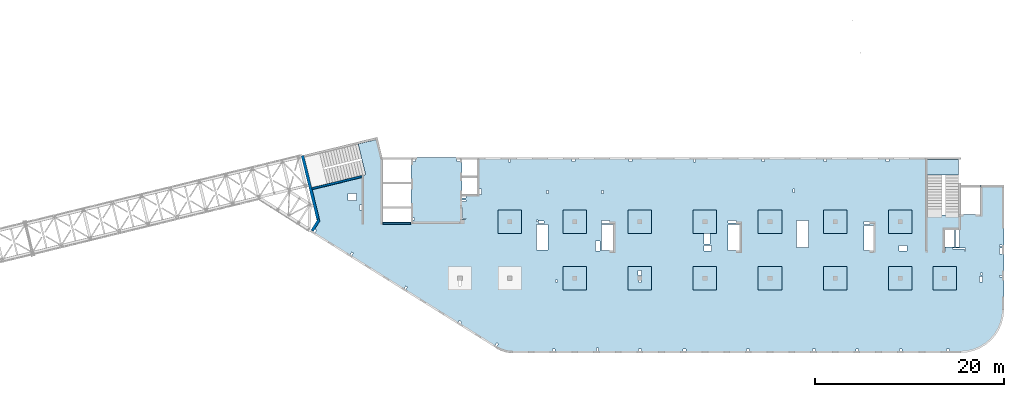
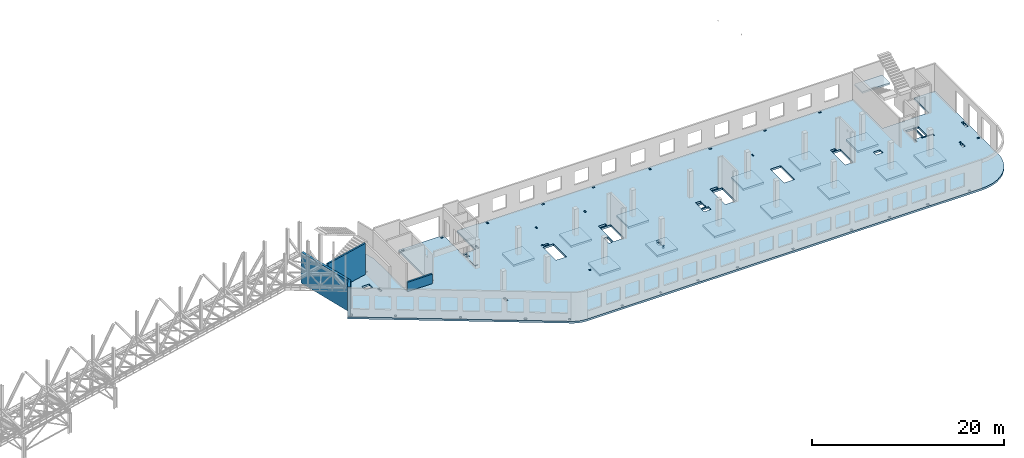
# One storey, part 20 of 92: 16 slabs, 4 walls.
"""IFC4 building model written with IfcOpenShell, lengths in millimetres."""

from ifc_helpers import new_model, entity, si_unit, converted_unit, derived_unit, direction, frame, origin, place, context, subcontext, project, spatial, indexed_curve, outline, extrude, material, type_object, element, save


model = new_model("IFC4")

# Units and contexts
model_context = context("Model", 3, precision=0.01, world=origin(), true_north=direction((6.12303176911189e-17, 1.0)))
plan_context = context("Plan", 3, precision=0.01, world=origin(), true_north=direction((6.12303176911189e-17, 1.0)))
body_context = subcontext(model_context, "Body", "Model", "MODEL_VIEW")
ifc_project = project(units=[si_unit("LENGTHUNIT", "METRE", prefix="MILLI"), si_unit("AREAUNIT", "SQUARE_METRE"), si_unit("VOLUMEUNIT", "CUBIC_METRE"), converted_unit("PLANEANGLEUNIT", "DEGREE", entity("IfcRatioMeasure", 0.0174532925199433), si_unit("PLANEANGLEUNIT", "RADIAN"), dimensions=[0, 0, 0, 0, 0, 0, 0]), si_unit("MASSUNIT", "GRAM", prefix="KILO"), derived_unit("MASSDENSITYUNIT", [(si_unit("MASSUNIT", "GRAM", prefix="KILO"), 1), (si_unit("LENGTHUNIT", "METRE"), -3)]), derived_unit("MOMENTOFINERTIAUNIT", [(si_unit("LENGTHUNIT", "METRE"), 4)]), si_unit("TIMEUNIT", "SECOND"), si_unit("FREQUENCYUNIT", "HERTZ"), si_unit("THERMODYNAMICTEMPERATUREUNIT", "DEGREE_CELSIUS"), derived_unit("THERMALTRANSMITTANCEUNIT", [(si_unit("MASSUNIT", "GRAM", prefix="KILO"), 1), (si_unit("THERMODYNAMICTEMPERATUREUNIT", "KELVIN"), -1), (si_unit("TIMEUNIT", "SECOND"), -3)]), derived_unit("VOLUMETRICFLOWRATEUNIT", [(si_unit("LENGTHUNIT", "METRE"), 3), (si_unit("TIMEUNIT", "SECOND"), -1)]), derived_unit("MASSFLOWRATEUNIT", [(si_unit("MASSUNIT", "GRAM", prefix="KILO"), 1), (si_unit("TIMEUNIT", "SECOND"), -1)]), derived_unit("ROTATIONALFREQUENCYUNIT", [(si_unit("TIMEUNIT", "SECOND"), -1)]), si_unit("ELECTRICCURRENTUNIT", "AMPERE"), si_unit("ELECTRICVOLTAGEUNIT", "VOLT"), si_unit("POWERUNIT", "WATT"), si_unit("FORCEUNIT", "NEWTON", prefix="KILO"), si_unit("ILLUMINANCEUNIT", "LUX"), si_unit("LUMINOUSFLUXUNIT", "LUMEN"), si_unit("LUMINOUSINTENSITYUNIT", "CANDELA"), derived_unit("USERDEFINED", [(si_unit("MASSUNIT", "GRAM", prefix="KILO"), -1), (si_unit("LENGTHUNIT", "METRE"), -2), (si_unit("TIMEUNIT", "SECOND"), 3), (si_unit("LUMINOUSFLUXUNIT", "LUMEN"), 1)]), derived_unit("LINEARVELOCITYUNIT", [(si_unit("LENGTHUNIT", "METRE"), 1), (si_unit("TIMEUNIT", "SECOND"), -1)]), si_unit("PRESSUREUNIT", "PASCAL"), derived_unit("USERDEFINED", [(si_unit("LENGTHUNIT", "METRE"), -2), (si_unit("MASSUNIT", "GRAM", prefix="KILO"), 1), (si_unit("TIMEUNIT", "SECOND"), -2)]), derived_unit("LINEARFORCEUNIT", [(si_unit("MASSUNIT", "GRAM", prefix="KILO"), 1), (si_unit("LENGTHUNIT", "METRE"), 1), (si_unit("TIMEUNIT", "SECOND"), -2), (si_unit("LENGTHUNIT", "METRE"), -1)]), derived_unit("PLANARFORCEUNIT", [(si_unit("MASSUNIT", "GRAM", prefix="KILO"), 1), (si_unit("LENGTHUNIT", "METRE"), 1), (si_unit("TIMEUNIT", "SECOND"), -2), (si_unit("LENGTHUNIT", "METRE"), -2)])], contexts=[model_context, plan_context])

# Site, building, storey
site_placement = place(None, origin())
site = spatial("IfcSite", under=ifc_project, at=site_placement, CompositionType="ELEMENT")
building_placement = place(site_placement, origin())
building = spatial("IfcBuilding", under=site, at=building_placement, CompositionType="ELEMENT")
storey_placement = place(building_placement, frame((0.0, 0.0, 15900.0)))
storey = spatial("IfcBuildingStorey", under=building, at=storey_placement, Name="05", CompositionType="ELEMENT", Elevation=15900.0)

# Slabs
ifc_material = material()
slab_type_1 = type_object("IfcSlabType", Name=":ADSK_ 25_250", PredefinedType="FLOOR", material=ifc_material)
placement = place(storey_placement, origin())
element("IfcSlab", 1, at=placement, inside=storey, type_object=slab_type_1, material=ifc_material, Name=":ADSK_ 25_250", ObjectType=":ADSK_ 25_250", PredefinedType="FLOOR", context=body_context, shape_type="SweptSolid", body=[
    extrude(outline(indexed_curve([(-11615.3456191022, -15866.2384672249), (-11461.2227621515, -15956.6617307079), (-11302.2940263976, -16038.3432987954), (-11139.0547290428, -16111.0286027615), (-10972.0136215827, -16174.4911116315), (-10801.6913042325, -16228.5330381886), (-10628.6186034238, -16272.985955397), (-10453.3349174317, -16307.7113213217), (-10276.3865352866, -16332.6009109081), (-10098.3249342096, -16347.5771532763), (-9919.70506087959, -16352.5933734784), (37585.2949391216, -16352.5933734786), (38304.8933503634, -16295.9597502856), (39006.7728605103, -16127.4533884657), (39673.6508666178, -15851.2234738877), (40289.1066189344, -15474.0717038028), (40837.9855542575, -15005.2848064856), (41306.7724515748, -14456.4058711625), (41683.9242216596, -13840.9501188459), (41960.1541362377, -13174.0721127383), (42128.6604980575, -12472.1926025915), (42185.2941212505, -11752.5941913496), (42185.2941212505, 1417.40662652148), (39685.2941212505, 1417.40662652149), (39685.2941212505, -1682.59337347851), (37385.2949391216, -1682.59337347851), (37385.2949391216, -1722.59337347848), (34045.2949391217, -1722.59337347847), (34045.2949391217, 4347.4072658887), (-13659.7050608784, 4347.40726588886), (-13659.7050608784, 447.406626521855), (-15284.7050608784, 447.406626521859), (-15284.7050608784, 4347.40726588869), (-20684.7050608784, 4347.40726588871), (-20684.7050608784, -2502.5933734781), (-23684.7050608784, -2502.59337347809), (-23684.7050608784, 4347.40726588869), (-23734.0606732206, 4347.40726588869), (-24254.10794231, 6480.84192351009), (-24448.4183539383, 6433.47670491202), (-24401.0531353402, 6239.16629328373), (-26276.1486075532, 5782.09193381237), (-25485.1529405355, 2537.12235056864), (-31479.6214345329, 1075.90723492907), (-30648.3195083992, -2334.4141830962), (-31384.8454167592, -3513.12502953493), (-11615.3456191022, -15866.2384672249)], self_intersect=False), holes=[indexed_curve([(-26424.7050608784, -192.593373478052), (-27324.7050608784, -192.593373478052), (-27324.7050608784, 507.406626521949), (-26424.7050608784, 507.406626521947), (-26424.7050608784, -192.593373478052)], self_intersect=False), indexed_curve([(-25884.7050608784, -667.593373478048), (-25884.7050608784, -1227.59337347805), (-26134.7050608784, -1227.59337347805), (-26134.7050608784, -667.593373478048), (-25884.7050608784, -667.593373478048)], self_intersect=False), indexed_curve([(-30865.4736804199, -3248.07220556975), (-30695.8631316644, -3354.05457085215), (-30854.836679588, -3608.47039398543), (-31024.4472283436, -3502.48802870303), (-30865.4736804199, -3248.07220556975)], self_intersect=False), indexed_curve([(-26955.9505316053, -5690.96572532919), (-26786.3399828498, -5796.94809061159), (-26945.3135307734, -6051.36391374487), (-27114.9240795289, -5945.38154846246), (-26955.9505316053, -5690.96572532919)], self_intersect=False), indexed_curve([(-21223.1139836689, -9273.16967187448), (-21053.5034349134, -9379.15203715688), (-21212.476982837, -9633.56786029016), (-21382.0875315925, -9527.58549500775), (-21223.1139836689, -9273.16967187448)], self_intersect=False), indexed_curve([(-15551.7491458115, -12934.8797745334), (-15297.3333226782, -13093.853322457), (-15403.3156879606, -13263.4638712125), (-15657.7315110939, -13104.4903232889), (-15551.7491458115, -12934.8797745334)], self_intersect=False), indexed_curve([(-11580.7542869179, -15298.2671381792), (-11411.1437381624, -15404.2495034616), (-11570.117286086, -15658.6653265949), (-11739.7278348415, -15552.6829613125), (-11580.7542869179, -15298.2671381792)], self_intersect=False), indexed_curve([(-5384.7050608784, -16152.5933734782), (-5684.7050608784, -16152.5933734782), (-5684.7050608784, -15952.5933734782), (-5384.7050608784, -15952.5933734782), (-5384.7050608784, -16152.5933734782)], self_intersect=False), indexed_curve([(-789.705060878393, -16152.5933734782), (-989.705060878395, -16152.5933734782), (-989.705060878386, -15852.5933734782), (-789.705060878388, -15852.5933734782), (-789.705060878393, -16152.5933734782)], self_intersect=False), indexed_curve([(3735.29493912161, -16152.5933734782), (3435.29493912161, -16152.5933734782), (3435.29493912161, -15952.5933734782), (3735.29493912161, -15952.5933734782), (3735.29493912161, -16152.5933734782)], self_intersect=False), indexed_curve([(8485.29493912161, -16152.5933734783), (8185.29493912161, -16152.5933734782), (8185.29493912161, -15952.5933734782), (8485.29493912161, -15952.5933734783), (8485.29493912161, -16152.5933734783)], self_intersect=False), indexed_curve([(15185.2949391216, -16152.5933734783), (14885.2949391216, -16152.5933734782), (14885.2949391216, -15952.5933734783), (15185.2949391216, -15952.5933734783), (15185.2949391216, -16152.5933734783)], self_intersect=False), indexed_curve([(22185.2949391216, -16152.5933734783), (21885.2949391216, -16152.5933734783), (21885.2949391216, -15952.5933734783), (22185.2949391216, -15952.5933734783), (22185.2949391216, -16152.5933734783)], self_intersect=False), indexed_curve([(26785.2949391216, -16152.5933734783), (26485.2949391216, -16152.5933734783), (26485.2949391216, -15952.5933734783), (26785.2949391216, -15952.5933734783), (26785.2949391216, -16152.5933734783)], self_intersect=False), indexed_curve([(31385.2949391216, -16152.5933734783), (31085.2949391216, -16152.5933734783), (31085.2949391216, -15952.5933734783), (31385.2949391216, -15952.5933734783), (31385.2949391216, -16152.5933734783)], self_intersect=False), indexed_curve([(36385.2949391216, -16152.5933734783), (36085.2949391216, -16152.5933734783), (36085.2949391216, -15952.5933734783), (36385.2949391216, -15952.5933734783), (36385.2949391216, -16152.5933734783)], self_intersect=False), indexed_curve([(-20184.7050608784, 4147.4072658887), (-20184.7050608784, 3947.4072658887), (-20484.7050608784, 3947.40726588869), (-20484.7050608784, 4147.4072658887), (-20184.7050608784, 4147.4072658887)], self_intersect=False), indexed_curve([(-20284.7050608784, -2252.59337347809), (-20484.7050608784, -2252.59337347809), (-20484.7050608784, -2052.59337347809), (-20284.7050608784, -2052.59337347809), (-20284.7050608784, -2252.59337347809)], self_intersect=False), indexed_curve([(-15784.7050608784, 4147.4072658887), (-15484.7050608784, 4147.4072658887), (-15484.7050608784, 3947.4072658887), (-15784.7050608784, 3947.4072658887), (-15784.7050608784, 4147.4072658887)], self_intersect=False), indexed_curve([(-14854.7050608784, 247.406626521861), (-14854.7050608784, 47.4066265218589), (-15284.7050608784, 47.4066265218589), (-15284.7050608784, 247.406626521859), (-14854.7050608784, 247.406626521861)], self_intersect=False), indexed_curve([(-14854.7050608784, -177.593373478142), (-14854.7050608784, -337.59337347814), (-15284.7050608784, -337.59337347814), (-15284.7050608784, -177.593373478142), (-14854.7050608784, -177.593373478142)], self_intersect=False), indexed_curve([(-15284.7050608784, -2182.59337347814), (-15284.7050608784, -992.593373478139), (-15204.7050608784, -992.593373478139), (-15204.7050608784, -2102.59337347814), (-14864.7050608784, -2102.59337347814), (-14864.7050608784, -2182.59337347814), (-15284.7050608784, -2182.59337347814)], self_intersect=False), indexed_curve([(-13209.7050608784, 447.406626521855), (-13459.7050608784, 447.406626521855), (-13459.7050608784, 1007.40662652186), (-13209.7050608784, 1007.40662652186), (-13209.7050608784, 447.406626521855)], self_intersect=False), indexed_curve([(-10314.7050608784, 4147.4072658887), (-10214.7050608784, 4147.4072658887), (-10114.7050608784, 4147.40662652183), (-10114.7050608784, 3847.40726588869), (-10314.7050608784, 3847.40726588869), (-10314.7050608784, 4147.4072658887)], self_intersect=False), indexed_curve([(-3614.70506087836, 4147.40662652179), (-3314.70506087836, 4147.40662652179), (-3314.70506087836, 3947.40662652179), (-3614.70506087836, 3947.40662652179), (-3614.70506087836, 4147.40662652179)], self_intersect=False), indexed_curve([(2460.29493912165, 4147.40662652177), (2760.29493912165, 4147.40662652177), (2760.29493912164, 3947.40662652177), (2460.29493912164, 3947.40662652176), (2460.29493912165, 4147.40662652177)], self_intersect=False), indexed_curve([(16510.2949391216, 4147.40662652173), (16810.2949391216, 4147.40662652172), (16810.2949391216, 3947.40662652171), (16510.2949391216, 3947.40662652172), (16510.2949391216, 4147.40662652173)], self_intersect=False), indexed_curve([(9260.29493912165, 4147.4066265217), (9460.29493912165, 4147.4066265217), (9460.29493912166, 3847.4066265217), (9260.29493912165, 3847.4066265217), (9260.29493912165, 4147.4066265217)], self_intersect=False), indexed_curve([(23085.2949391216, 4147.40662652169), (23385.2949391216, 4147.40662652169), (23385.2949391216, 3947.4066265217), (23085.2949391216, 3947.4066265217), (23085.2949391216, 4147.40662652169)], self_intersect=False), indexed_curve([(29685.2949391216, 4147.40662652168), (29985.2949391216, 4147.40662652167), (29985.2949391216, 3947.40662652167), (29685.2949391216, 3947.40662652167), (29685.2949391216, 4147.40662652168)], self_intersect=False), indexed_curve([(-6114.70506087836, 847.407265888692), (-6114.70506087836, 527.407265888689), (-6314.70506087837, 527.407265888691), (-6314.70506087837, 847.407265888695), (-6114.70506087836, 847.407265888692)], self_intersect=False), indexed_curve([(-264.705060878365, 867.407265888811), (-264.70506087836, 507.407265888813), (-464.705060878358, 507.407265888813), (-464.705060878358, 867.407265888811), (-264.705060878365, 867.407265888811)], self_intersect=False), indexed_curve([(19975.2949391216, 997.407265888704), (19975.2949391216, 647.407265888701), (19825.2949391216, 647.407265888701), (19825.2949391216, 997.407265888704), (19975.2949391216, 997.407265888704)], self_intersect=False), indexed_curve([(37055.2949391217, -5127.59337347849), (37055.2949391217, -3322.59337347848), (37385.2949391216, -3322.59337347849), (37445.2949391217, -3322.59337347849), (37445.2949391217, -5127.59337347849), (37055.2949391217, -5127.59337347849)], self_intersect=False), indexed_curve([(35975.2949391217, -5247.59337347849), (35975.2949391217, -5587.59337347849), (35895.2949391217, -5587.59337347849), (35895.2949391217, -5247.59337347849), (35975.2949391217, -5247.59337347849)], self_intersect=False), indexed_curve([(38095.2949391216, -5247.59337347848), (38095.2949391216, -5587.59337347848), (38015.2949391216, -5587.59337347849), (38015.2949391216, -5327.59337347848), (36715.2949391216, -5327.59337347848), (36715.2949391216, -5247.59337347849), (38095.2949391216, -5247.59337347848)], self_intersect=False), indexed_curve([(41685.2941212505, -8342.59337347853), (41685.2941212505, -8142.59337347853), (41985.2941212505, -8142.59337347853), (41985.2941212505, -8342.59337347853), (41685.2941212505, -8342.59337347853)], self_intersect=False), indexed_curve([(41685.2941212505, -5102.59337347853), (41685.2941212505, -4902.59337347852), (41985.2941212505, -4902.59337347853), (41985.2941212505, -5102.59337347853), (41685.2941212505, -5102.59337347853)], self_intersect=False), indexed_curve([(41685.2941212505, -5867.59337347854), (41685.2941212505, -5267.59337347853), (41985.2941212505, -5267.59337347854), (41985.2941212505, -5867.59337347854), (41685.2941212505, -5867.59337347854)], self_intersect=False), indexed_curve([(39895.2941212505, -8272.5933734785), (39895.2941212505, -8852.59337347852), (39595.2941212505, -8852.59337347852), (39595.2941212505, -8272.59337347851), (39895.2941212505, -8272.5933734785)], self_intersect=False), indexed_curve([(39905.2941212505, -7892.59337347851), (39905.2941212505, -8092.59337347851), (39705.2941212505, -8092.59337347851), (39705.2941212505, -7892.5933734785), (39905.2941212505, -7892.59337347851)], self_intersect=False), indexed_curve([(31900.2949391216, -4967.59337347845), (31900.2949391216, -5567.59337347845), (31070.2949391216, -5567.59337347845), (31070.2949391216, -4967.59337347845), (31900.2949391216, -4967.59337347845)], self_intersect=False), indexed_curve([(27345.2949391216, -5527.59337347843), (27345.2949391216, -2857.59337347842), (28345.2949391217, -2857.59337347842), (28345.2949391217, -5527.59337347844), (27345.2949391216, -5527.59337347843)], self_intersect=False), indexed_curve([(27345.2949391216, -2452.59337347842), (27945.2949391216, -2452.59337347842), (27945.2949391216, -2737.59337347842), (27345.2949391216, -2737.59337347842), (27345.2949391216, -2452.59337347842)], self_intersect=False), indexed_curve([(21465.2949391216, -2317.59337347838), (21465.2949391216, -5177.59337347839), (20205.2949391216, -5177.59337347839), (20205.2949391216, -2317.59337347838), (21465.2949391216, -2317.59337347838)], self_intersect=False), indexed_curve([(12925.2949391216, -5527.59322391854), (12925.2949391216, -2752.59322391854), (14185.2949391216, -2752.59322391854), (14185.2949391216, -5527.59322391853), (12925.2949391216, -5527.59322391854)], self_intersect=False), indexed_curve([(12925.2949391216, -2602.59337347834), (12925.2949391216, -2312.59337347833), (13785.2949391216, -2312.59337347833), (13785.2949391216, -2602.59337347834), (12925.2949391216, -2602.59337347834)], self_intersect=False), indexed_curve([(10395.2949391217, -3702.59337347839), (10485.2949391216, -3702.59337347838), (11015.2949391216, -3702.59337347839), (11015.2949391216, -4822.59337347839), (10395.2949391217, -4822.59337347839), (10395.2949391217, -3702.59337347839)], self_intersect=False), indexed_curve([(10370.2949391216, -4967.59337347839), (11200.2949391216, -4967.59337347839), (11200.2949391216, -5567.59337347838), (10370.2949391216, -5567.59337347839), (10370.2949391216, -4967.59337347839)], self_intersect=False), indexed_curve([(3485.29493912162, -8702.59337347826), (3585.29493912162, -8702.59337347826), (3685.29493912163, -8702.59337347826), (3685.29493912163, -8902.59337347827), (3485.29493912163, -8902.59337347827), (3485.29493912162, -8702.59337347826)], self_intersect=False), indexed_curve([(3405.29493912162, -8162.59337347827), (3405.29493912162, -7652.59337347826), (3735.29493912162, -7652.59337347827), (3735.29493912162, -8162.59337347826), (3405.29493912162, -8162.59337347827)], self_intersect=False), indexed_curve([(-474.705060878365, -5527.5932239185), (-474.705060878365, -2752.5932239185), (785.29493912163, -2752.5932239185), (785.294939121635, -5527.59322391849), (-474.705060878365, -5527.5932239185)], self_intersect=False), indexed_curve([(-474.705060878365, -2312.59337347824), (385.29493912163, -2312.59337347824), (385.294939121626, -2632.59337347824), (-474.705060878369, -2632.59337347824), (-474.705060878365, -2312.59337347824)], self_intersect=False), indexed_curve([(-1094.70506087836, -5567.5932239185), (-1094.70506087837, -4477.5932239185), (-634.705060878363, -4477.5932239185), (-634.705060878363, -5567.5932239185), (-1094.70506087836, -5567.5932239185)], self_intersect=False), indexed_curve([(-5134.70506087838, -8662.5933734782), (-5134.70506087839, -8862.5933734782), (-5334.70506087839, -8862.5933734782), (-5334.70506087839, -8662.5933734782), (-5134.70506087838, -8662.5933734782)], self_intersect=False), indexed_curve([(-6134.70506087837, -2752.59337347818), (-6134.70506087837, -5462.59337347818), (-7394.70506087837, -5462.59337347818), (-7394.70506087837, -2752.59337347818), (-6134.70506087837, -2752.59337347818)], self_intersect=False), indexed_curve([(-7194.70506087837, -2462.59337347819), (-7394.70506087837, -2462.59337347819), (-7394.70506087837, -2272.59337347818), (-7194.70506087837, -2272.59337347818), (-7194.70506087837, -2462.59337347819)], self_intersect=False), indexed_curve([(-6594.70506087837, -2632.59337347819), (-7154.70506087837, -2632.59337347819), (-7154.70506087837, -2382.5933734782), (-6594.70506087837, -2382.5933734782), (-6594.70506087837, -2632.59337347819)], self_intersect=False), indexed_curve([(36935.2949391217, -3322.59337347849), (36935.2949391217, -5127.59337347849), (35895.2949391217, -5127.59337347849), (35895.2949391217, -3322.59337347849), (36935.2949391217, -3322.59337347849)], self_intersect=False), indexed_curve([(-15644.7050608784, -8702.59337347814), (-15484.7050608784, -8702.59337347813), (-15394.7050608784, -8702.59337347813), (-15394.7050608784, -9262.59337347813), (-15644.7050608784, -9262.59337347814), (-15644.7050608784, -8702.59337347814)], self_intersect=False)]), frame((31384.71, 16152.59, -400.0)), (0.0, 0.0, 1.0), 249.999999999999),
])
slab_type_2 = type_object("IfcSlabType", Name=":ADSK_ 25_250", PredefinedType="FLOOR", material=ifc_material)
element("IfcSlab", 2, at=placement, inside=storey, type_object=slab_type_2, material=ifc_material, Name=":ADSK_ 25_250", ObjectType=":ADSK_ 25_250", PredefinedType="FLOOR", context=body_context, shape_type="SweptSolid", body=[
    extrude(outline(indexed_curve([(-1250.0, -1250.0), (1250.0, -1250.0), (1250.0, 1250.0), (-1250.0, 1250.0), (-1250.0, -1250.0)], self_intersect=False)), frame((28070.0, 7700.0, -400.0), z_axis=(0.0, 0.0, -1.0), x_axis=(0.0, 1.0, 0.0)), (0.0, 0.0, 1.0), 249.999999999999),
])
slab_type_3 = type_object("IfcSlabType", Name=":ADSK_ 25_250", PredefinedType="FLOOR", material=ifc_material)
element("IfcSlab", 3, at=placement, inside=storey, type_object=slab_type_3, material=ifc_material, Name=":ADSK_ 25_250", ObjectType=":ADSK_ 25_250", PredefinedType="FLOOR", context=body_context, shape_type="SweptSolid", body=[
    extrude(outline(indexed_curve([(-999.999999999999, -1250.00000000001), (1500.0, -1250.00000000001), (1500.0, 1250.0), (-999.999999999999, 1250.0), (-1000.0, -6.064055924071e-12), (-999.999999999999, -1250.00000000001)], self_intersect=False), holes=[indexed_curve([(500.000000000073, 99.9999999999998), (700.000000000076, 100.0), (700.000000000076, -100.000000000002), (500.000000000074, -100.000000000002), (500.000000000073, 99.9999999999998)], self_intersect=False), indexed_curve([(-549.999999999928, 149.999999999991), (-39.9999999999262, 149.999999999992), (-39.9999999999256, -180.000000000007), (-549.999999999928, -180.000000000008), (-549.999999999928, 149.999999999991)], self_intersect=False)]), frame((34970.0, 7950.0, -650.0), z_axis=(0.0, 0.0, 1.0), x_axis=(0.0, -1.0, 0.0)), (0.0, 0.0, 1.0), 249.999999999999),
])
slab_type_4 = type_object("IfcSlabType", Name=":ADSK_ 25_250", PredefinedType="FLOOR", material=ifc_material)
element("IfcSlab", 4, at=placement, inside=storey, type_object=slab_type_4, material=ifc_material, Name=":ADSK_ 25_250", ObjectType=":ADSK_ 25_250", PredefinedType="FLOOR", context=body_context, shape_type="SweptSolid", body=[
    extrude(outline(indexed_curve([(-1250.0, -1250.0), (1250.0, -1250.0), (1250.0, 1250.0), (-1250.0, 1250.0), (-1250.0, -1250.0)], self_intersect=False)), frame((41870.0, 7700.0, -400.0), z_axis=(0.0, 0.0, -1.0), x_axis=(0.0, 1.0, 0.0)), (0.0, 0.0, 1.0), 249.999999999999),
])
slab_type_5 = type_object("IfcSlabType", Name=":ADSK_ 25_250", PredefinedType="FLOOR", material=ifc_material)
element("IfcSlab", 5, at=placement, inside=storey, type_object=slab_type_5, material=ifc_material, Name=":ADSK_ 25_250", ObjectType=":ADSK_ 25_250", PredefinedType="FLOOR", context=body_context, shape_type="SweptSolid", body=[
    extrude(outline(indexed_curve([(-1250.0, -1250.0), (1250.0, -1250.0), (1250.0, 1250.0), (-1250.0, 1250.0), (-1250.0, -1250.0)], self_intersect=False)), frame((48770.0, 7700.0, -400.0), z_axis=(0.0, 0.0, -1.0), x_axis=(0.0, 1.0, 0.0)), (0.0, 0.0, 1.0), 249.999999999999),
])
slab_type_6 = type_object("IfcSlabType", Name=":ADSK_ 25_250", PredefinedType="FLOOR", material=ifc_material)
element("IfcSlab", 6, at=placement, inside=storey, type_object=slab_type_6, material=ifc_material, Name=":ADSK_ 25_250", ObjectType=":ADSK_ 25_250", PredefinedType="FLOOR", context=body_context, shape_type="SweptSolid", body=[
    extrude(outline(indexed_curve([(-1250.0, -1249.99999999999), (1250.0, -1249.99999999999), (1250.0, 1250.00000000001), (-1250.0, 1250.00000000001), (-1250.0, -1249.99999999999)], self_intersect=False)), frame((55670.0, 7700.0, -400.0), z_axis=(0.0, 0.0, -1.0), x_axis=(0.0, 1.0, 0.0)), (0.0, 0.0, 1.0), 249.999999999999),
])
slab_type_7 = type_object("IfcSlabType", Name=":ADSK_ 25_250", PredefinedType="FLOOR", material=ifc_material)
element("IfcSlab", 7, at=placement, inside=storey, type_object=slab_type_7, material=ifc_material, Name=":ADSK_ 25_250", ObjectType=":ADSK_ 25_250", PredefinedType="FLOOR", context=body_context, shape_type="SweptSolid", body=[
    extrude(outline(indexed_curve([(-1250.0, -1250.0), (1250.0, -1250.0), (1250.0, 1250.0), (-1250.0, 1250.0), (-1250.0, -1250.0)], self_intersect=False)), frame((62570.0, 7700.0, -400.0), z_axis=(0.0, 0.0, -1.0), x_axis=(0.0, 1.0, 0.0)), (0.0, 0.0, 1.0), 249.999999999999),
])
slab_type_8 = type_object("IfcSlabType", Name=":ADSK_ 25_250", PredefinedType="FLOOR", material=ifc_material)
element("IfcSlab", 8, at=placement, inside=storey, type_object=slab_type_8, material=ifc_material, Name=":ADSK_ 25_250", ObjectType=":ADSK_ 25_250", PredefinedType="FLOOR", context=body_context, shape_type="SweptSolid", body=[
    extrude(outline(indexed_curve([(-1250.0, -1249.99999999999), (1250.0, -1249.99999999999), (1250.0, 1250.00000000001), (-1250.0, 1250.00000000001), (-1250.0, -1249.99999999999)], self_intersect=False)), frame((67270.0, 7700.0, -400.0), z_axis=(0.0, 0.0, -1.0), x_axis=(0.0, 1.0, 0.0)), (0.0, 0.0, 1.0), 249.999999999999),
])
slab_type_9 = type_object("IfcSlabType", Name=":ADSK_ 25_250", PredefinedType="FLOOR", material=ifc_material)
element("IfcSlab", 9, at=placement, inside=storey, type_object=slab_type_9, material=ifc_material, Name=":ADSK_ 25_250", ObjectType=":ADSK_ 25_250", PredefinedType="FLOOR", context=body_context, shape_type="SweptSolid", body=[
    extrude(outline(indexed_curve([(-1250.0, -1250.0), (1250.0, -1250.0), (1250.0, 1250.0), (-1250.0, 1250.0), (-1250.0, -1250.0)], self_intersect=False)), frame((62570.0, 13700.0, -400.0), z_axis=(0.0, 0.0, -1.0), x_axis=(0.0, 1.0, 0.0)), (0.0, 0.0, 1.0), 249.999999999999),
])
slab_type_10 = type_object("IfcSlabType", Name=":ADSK_ 25_250", PredefinedType="FLOOR", material=ifc_material)
element("IfcSlab", 10, at=placement, inside=storey, type_object=slab_type_10, material=ifc_material, Name=":ADSK_ 25_250", ObjectType=":ADSK_ 25_250", PredefinedType="FLOOR", context=body_context, shape_type="SweptSolid", body=[
    extrude(outline(indexed_curve([(-1250.0, -1250.0), (1250.0, -1250.0), (1250.0, 1250.0), (-1250.0, 1250.0), (-1250.0, -1250.0)], self_intersect=False)), frame((55670.0, 13700.0, -400.0), z_axis=(0.0, 0.0, -1.0), x_axis=(0.0, 1.0, 0.0)), (0.0, 0.0, 1.0), 249.999999999999),
])
slab_type_11 = type_object("IfcSlabType", Name=":ADSK_ 25_250", PredefinedType="FLOOR", material=ifc_material)
element("IfcSlab", 11, at=placement, inside=storey, type_object=slab_type_11, material=ifc_material, Name=":ADSK_ 25_250", ObjectType=":ADSK_ 25_250", PredefinedType="FLOOR", context=body_context, shape_type="SweptSolid", body=[
    extrude(outline(indexed_curve([(-1250.0, -1250.0), (1250.0, -1250.0), (1250.0, 1250.0), (-1250.0, 1250.0), (-1250.0, -1250.0)], self_intersect=False)), frame((48770.0, 13700.0, -400.0), z_axis=(0.0, 0.0, -1.0), x_axis=(0.0, 1.0, 0.0)), (0.0, 0.0, 1.0), 249.999999999999),
])
slab_type_12 = type_object("IfcSlabType", Name=":ADSK_ 25_250", PredefinedType="FLOOR", material=ifc_material)
element("IfcSlab", 12, at=placement, inside=storey, type_object=slab_type_12, material=ifc_material, Name=":ADSK_ 25_250", ObjectType=":ADSK_ 25_250", PredefinedType="FLOOR", context=body_context, shape_type="SweptSolid", body=[
    extrude(outline(indexed_curve([(-1250.0, -1250.0), (1250.0, -1250.0), (1250.0, 1250.0), (-1250.0, 1250.0), (-1250.0, -1250.0)], self_intersect=False)), frame((41870.0, 13700.0, -400.0), z_axis=(0.0, 0.0, -1.0), x_axis=(0.0, 1.0, 0.0)), (0.0, 0.0, 1.0), 249.999999999999),
])
slab_type_13 = type_object("IfcSlabType", Name=":ADSK_ 25_250", PredefinedType="FLOOR", material=ifc_material)
element("IfcSlab", 13, at=placement, inside=storey, type_object=slab_type_13, material=ifc_material, Name=":ADSK_ 25_250", ObjectType=":ADSK_ 25_250", PredefinedType="FLOOR", context=body_context, shape_type="SweptSolid", body=[
    extrude(outline(indexed_curve([(-1250.0, -1250.0), (1250.0, -1250.0), (1250.0, 1250.0), (-1250.0, 1250.0), (-1250.0, -1250.0)], self_intersect=False)), frame((34970.0, 13700.0, -400.0), z_axis=(0.0, 0.0, -1.0), x_axis=(0.0, 1.0, 0.0)), (0.0, 0.0, 1.0), 249.999999999999),
])
slab_type_14 = type_object("IfcSlabType", Name=":ADSK_ 25_250", PredefinedType="FLOOR", material=ifc_material)
element("IfcSlab", 14, at=placement, inside=storey, type_object=slab_type_14, material=ifc_material, Name=":ADSK_ 25_250", ObjectType=":ADSK_ 25_250", PredefinedType="FLOOR", context=body_context, shape_type="SweptSolid", body=[
    extrude(outline(indexed_curve([(-1250.0, -1250.0), (1250.0, -1250.0), (1250.0, 1250.0), (-1250.0, 1250.0), (-1250.0, -1250.0)], self_intersect=False)), frame((28070.0, 13700.0, -400.0), z_axis=(0.0, 0.0, -1.0), x_axis=(0.0, 1.0, 0.0)), (0.0, 0.0, 1.0), 249.999999999999),
])
slab_type_15 = type_object("IfcSlabType", Name=":ADSK_ 25_250", PredefinedType="FLOOR", material=ifc_material)
element("IfcSlab", 15, at=placement, inside=storey, type_object=slab_type_15, material=ifc_material, Name=":ADSK_ 25_250", ObjectType=":ADSK_ 25_250", PredefinedType="FLOOR", context=body_context, shape_type="SweptSolid", body=[
    extrude(outline(indexed_curve([(-1250.0, -1250.0), (1250.0, -1250.0), (1250.0, 1250.0), (-1250.0, 1250.0), (-1250.0, -1250.0)], self_intersect=False)), frame((21170.0, 13700.0, -400.0), z_axis=(0.0, 0.0, -1.0), x_axis=(0.0, 1.0, 0.0)), (0.0, 0.0, 1.0), 249.999999999999),
])
slab_type_16 = type_object("IfcSlabType", Name=":ADSK_ 25_200", PredefinedType="FLOOR", material=ifc_material)
element("IfcSlab", 16, at=placement, inside=storey, type_object=slab_type_16, material=ifc_material, Name=":ADSK_ 25_200", ObjectType=":ADSK_ 25_200", PredefinedType="FLOOR", context=body_context, shape_type="SweptSolid", body=[
    extrude(outline(indexed_curve([(-834.999999999999, -1670.00000000001), (835.000000000001, -1670.00000000001), (835.000000000001, 1670.00000000002), (-834.999999999999, 1670.00000000002), (-834.999999999999, -1670.00000000001)], self_intersect=False)), frame((67100.0, 19465.0, 1920.0), z_axis=(0.0, 0.0, -1.0), x_axis=(0.0, 1.0, 0.0)), (0.0, 0.0, 1.0), 200.0),
])

# Walls
wall_type_1 = type_object("IfcWallType", Name=":ADSK_ 25_200", PredefinedType="STANDARD")
wall_1_placement = place(storey_placement, frame((220.24, 17202.38, -150.0), z_axis=(0.0, 0.0, 1.0), x_axis=(0.971552058141473, 0.236826092990338, 0.0)))
element("IfcWall", 17, at=wall_1_placement, inside=storey, type_object=wall_type_1, material=ifc_material, Name=":ADSK_ 25_200", ObjectType=":ADSK_ 25_200", PredefinedType="NOTDEFINED", context=body_context, shape_type="SweptSolid", body=[
    extrude(outline(indexed_curve([(5409.98499256816, -99.9999999999997), (5458.73710852649, 100.000000000002), (6.34492458573277e-13, 100.000000000002), (1.7427392862146e-12, -99.9999999999982), (5409.98499256816, -99.9999999999997)], self_intersect=False)), origin(), (0.0, 0.0, 1.0), 3950.0),
])
wall_2_placement = place(storey_placement, frame((7700.0, 13550.0, -150.0)))
element("IfcWall", 18, at=wall_2_placement, inside=storey, type_object=wall_type_1, material=ifc_material, Name=":ADSK_ 25_200", ObjectType=":ADSK_ 25_200", PredefinedType="NOTDEFINED", context=body_context, shape_type="SweptSolid", body=[
    extrude(outline(indexed_curve([(3000.0, 99.9999999999989), (-2.88764567812902e-13, 99.9999999999989), (2.88764567812902e-13, -99.9999999999989), (3000.0, -99.9999999999989), (3000.0, 99.9999999999989)], self_intersect=False)), origin(), (0.0, 0.0, 1.0), 1200.0),
])
wall_type_2 = type_object("IfcWallType", Name=":ADSK_ 25_300", PredefinedType="STANDARD")
wall_3_placement = place(storey_placement, frame((233.05, 12729.59, -150.0), z_axis=(0.0, 0.0, 1.0), x_axis=(0.529911826412024, 0.848052743777575, 0.0)))
element("IfcWall", 19, at=wall_3_placement, inside=storey, type_object=wall_type_2, material=ifc_material, Name=":ADSK_ 25_300", ObjectType=":ADSK_ 25_300", PredefinedType="NOTDEFINED", context=body_context, shape_type="SweptSolid", body=[
    extrude(outline(indexed_curve([(1316.31557757947, -150.0), (1609.08571844498, 150.0), (2.08113526412035e-12, 150.0), (9.05209240897875e-13, -150.0), (1316.31557757947, -150.0)], self_intersect=False)), origin(), (0.0, 0.0, 1.0), 3650.0),
])
wall_4_placement = place(storey_placement, frame((-787.54, 20703.3, -400.0), z_axis=(0.0, 0.0, 1.0), x_axis=(0.236826092990339, -0.971552058141473, 0.0)))
element("IfcWall", 20, at=wall_4_placement, inside=storey, type_object=wall_type_2, material=ifc_material, Name=":ADSK_ 25_300", ObjectType=":ADSK_ 25_300", PredefinedType="NOTDEFINED", context=body_context, shape_type="SweptSolid", body=[
    extrude(outline(indexed_curve([(7050.16407046696, -150.0), (6757.39392960146, 150.0), (-2.49567033705489e-13, 150.0), (1.86117787848161e-13, -150.0), (7050.16407046696, -150.0)], self_intersect=False)), origin(), (0.0, 0.0, 1.0), 3900.0),
])

save(model, "model.ifc")
